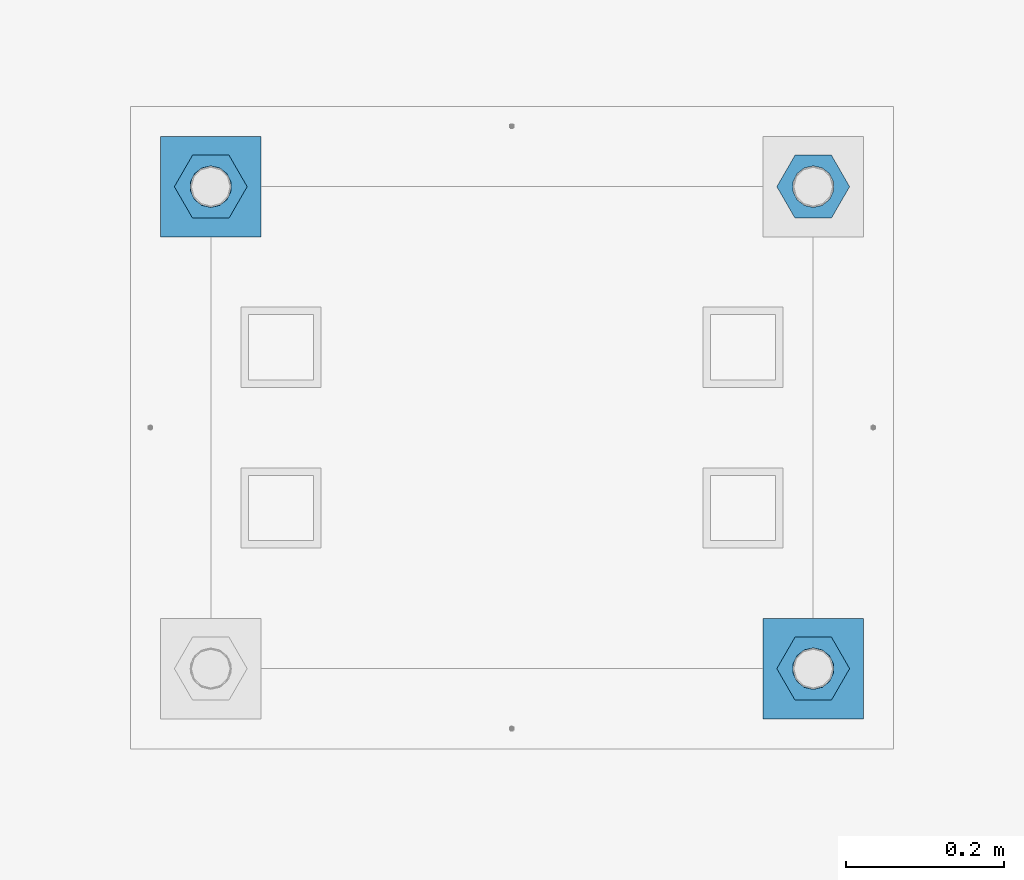
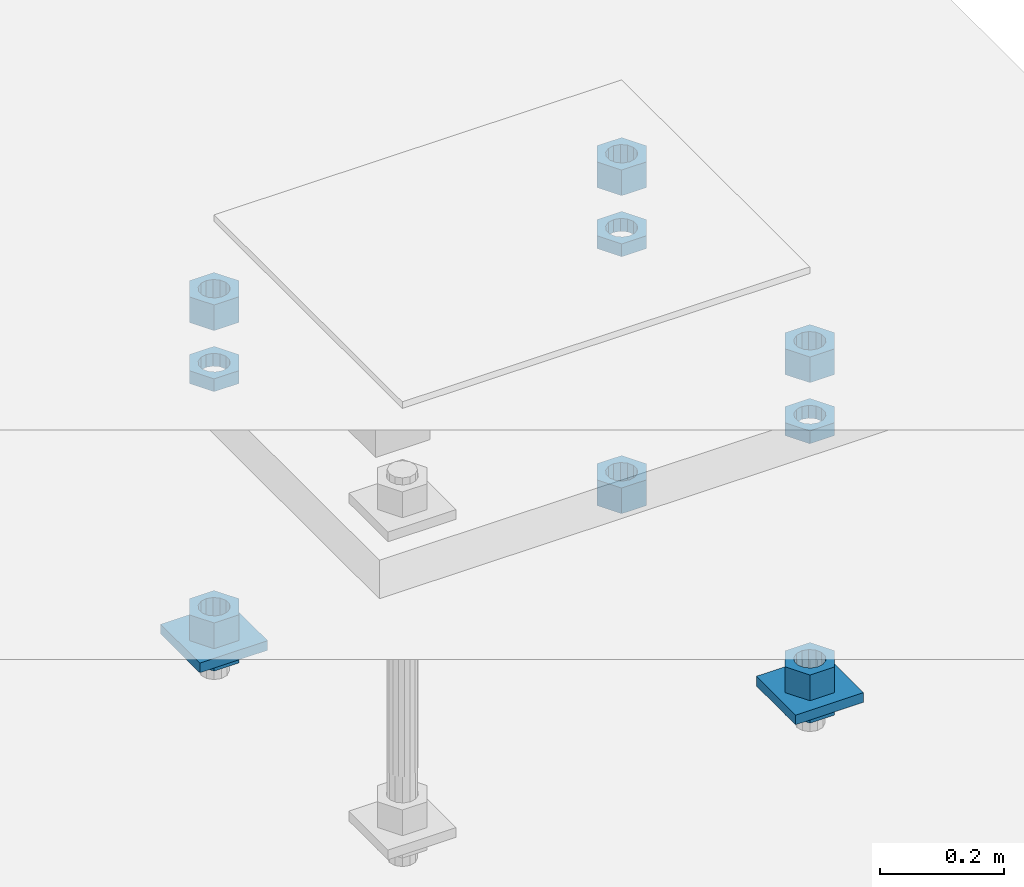
# One storey, part 2635 of 3843: 13 beams, 1 element without a shape of its own.
"""IFC2X3 building model written with IfcOpenShell, lengths in millimetres."""

import ifcopenshell
import ifcopenshell.guid

model = None  # the IFC model being written
_history = None  # IfcOwnerHistory: only IFC2X3 demands one
_inside = {}  # id of a spatial element -> (the spatial element, [elements in it])
_under = {}  # id of a project, library or spatial element -> (it, [spatial elements below it])
_declared = {}  # id of a project -> (the project, [libraries it declares])
_typed = {}  # id of a type object -> (the type object, [elements of that type])
_made_of = {}  # id of a material, layer set ... -> (it, [elements and type objects made of it])


def new_model(schema):
    """Start an empty IFC model of exactly this schema.

    Asked for "IFC4X3", IfcOpenShell would pick the latest addendum, in which some entities
    have other attributes; the version numbers below select the first issue.
    IFC2X3 requires an IfcOwnerHistory on every rooted entity: one is made here for all.
    """
    global model, _history
    if schema == "IFC4X3":
        model = ifcopenshell.file(schema_version=(4, 3, 0, 0))
    else:
        model = ifcopenshell.file(schema=schema)
    _inside.clear()
    _under.clear()
    _declared.clear()
    _typed.clear()
    _made_of.clear()
    _history = None
    if model.schema == "IFC2X3":
        org = make("IfcOrganization", Name="unknown")
        user = make(
            "IfcPersonAndOrganization",
            ThePerson=make("IfcPerson", FamilyName="unknown"),
            TheOrganization=org,
        )
        app = make(
            "IfcApplication",
            ApplicationDeveloper=org,
            Version="unknown",
            ApplicationFullName="unknown",
            ApplicationIdentifier="unknown",
        )
        _history = make(
            "IfcOwnerHistory",
            OwningUser=user,
            OwningApplication=app,
            ChangeAction="ADDED",
            CreationDate=0,
        )
    return model


def make(cls, **values):
    """One entity of the class cls with the attributes given. An attribute that is None is left unset."""
    return model.create_entity(
        cls, **{name: value for name, value in values.items() if value is not None}
    )


def rooted(cls, **values):
    """An entity with a GlobalId (a new one), such as an element, a storey or a relation."""
    return make(cls, GlobalId=ifcopenshell.guid.new(), OwnerHistory=_history, **values)


def si_unit(unit_type, name, prefix=None):
    """IfcSIUnit, for example si_unit("LENGTHUNIT", "METRE", prefix="MILLI")."""
    return make("IfcSIUnit", UnitType=unit_type, Prefix=prefix, Name=name)


def assignment(units):
    """IfcUnitAssignment: the units of a project."""
    return None if units is None else make("IfcUnitAssignment", Units=units)


def point(xyz):
    """IfcCartesianPoint."""
    return None if xyz is None else make("IfcCartesianPoint", Coordinates=xyz)


def direction(xyz):
    """IfcDirection."""
    return None if xyz is None else make("IfcDirection", DirectionRatios=xyz)


def frame(location, z_axis=None, x_axis=None):
    """IfcAxis2Placement3D, a coordinate frame: its origin and axes. An axis left out is left unset."""
    return make(
        "IfcAxis2Placement3D",
        Location=point(location),
        Axis=direction(z_axis),
        RefDirection=direction(x_axis),
    )


def origin_with_axes():
    """The frame at (0, 0, 0) with the z axis (0, 0, 1) and the x axis (1, 0, 0) written out."""
    return frame((0.0, 0.0, 0.0), z_axis=(0.0, 0.0, 1.0), x_axis=(1.0, 0.0, 0.0))


def place(relative_to, where):
    """IfcLocalPlacement: puts the frame where relative to a parent placement (None: the world)."""
    return make(
        "IfcLocalPlacement", PlacementRelTo=relative_to, RelativePlacement=where
    )


def context(
    kind, dimensions, precision=None, world=None, true_north=None, identifier=None
):
    """IfcGeometricRepresentationContext, for example the 3D "Model" context."""
    return make(
        "IfcGeometricRepresentationContext",
        ContextIdentifier=identifier,
        ContextType=kind,
        CoordinateSpaceDimension=dimensions,
        Precision=precision,
        WorldCoordinateSystem=world,
        TrueNorth=true_north,
    )


def subcontext(parent, identifier, kind, view, scale=None):
    """IfcGeometricRepresentationSubContext, for example "Body" below "Model"."""
    return make(
        "IfcGeometricRepresentationSubContext",
        ContextIdentifier=identifier,
        ContextType=kind,
        ParentContext=parent,
        TargetScale=scale,
        TargetView=view,
    )


def project(units=None, contexts=None):
    """IfcProject with its units and contexts."""
    return rooted(
        "IfcProject",
        Name="project",
        RepresentationContexts=contexts,
        UnitsInContext=assignment(units),
    )


def spatial(cls, under=None, at=None, **own):
    """A site, building, storey or space (cls), placed at a placement, below another one or the project."""
    s = rooted(cls, ObjectPlacement=at, **own)
    if under is not None:
        _under.setdefault(under.id(), (under, []))[1].append(s)
    return s


def faces_of(points, faces, orient=None, outer=None):
    """IfcFace entities. A face is a list of loops; a loop is a list of indices into points, from 0.

    orient and outer hold one flag for each loop. By default every Orientation is true, the
    first loop of a face is its IfcFaceOuterBound and the others are IfcFaceBound.
    """
    made = []
    for i, loops in enumerate(faces):
        bounds = []
        for j, loop in enumerate(loops):
            is_outer = j == 0 if outer is None else outer[i][j]
            bounds.append(
                make(
                    "IfcFaceOuterBound" if is_outer else "IfcFaceBound",
                    Bound=make("IfcPolyLoop", Polygon=[points[k] for k in loop]),
                    Orientation=True if orient is None else orient[i][j],
                )
            )
        made.append(make("IfcFace", Bounds=bounds))
    return made


def faceted_brep(points, faces, orient=None, outer=None, voids=None):
    """IfcFacetedBrep: a solid bounded by flat faces; with voids (closed shells), ...WithVoids."""
    shared = [point(p) for p in points]
    hull = make("IfcClosedShell", CfsFaces=faces_of(shared, faces, orient, outer))
    if voids is None:
        return make("IfcFacetedBrep", Outer=hull)
    return make(
        "IfcFacetedBrepWithVoids",
        Outer=hull,
        Voids=[
            make(cls, CfsFaces=faces_of(shared, fs, o, b)) for cls, fs, o, b in voids
        ],
    )


def shape(context_of_items, identifier, shape_type, items):
    """IfcShapeRepresentation: the items that make up one representation, for example the "Body"."""
    return make(
        "IfcShapeRepresentation",
        ContextOfItems=context_of_items,
        RepresentationIdentifier=identifier,
        RepresentationType=shape_type,
        Items=items,
    )


def material(Name=None, Category=None):
    """IfcMaterial."""
    return make("IfcMaterial", Name=Name, Category=Category)


def made_of(thing, what):
    """Note that an element or type object is made of a material, layer set ...; save() writes the relation."""
    if what is not None:
        _made_of.setdefault(what.id(), (what, []))[1].append(thing)
    return thing


def type_object(cls, material=None, **own):
    """A type object (cls), such as IfcWallType, which elements share."""
    return made_of(rooted(cls, **own), material)


def element(
    cls,
    number,
    at=None,
    inside=None,
    cuts=None,
    type_object=None,
    material=None,
    context=None,
    identifier="Body",
    shape_type=None,
    held_by="IfcProductDefinitionShape",
    body=None,
    shapes=None,
    **own,
):
    """One element of the class cls, such as IfcWall. Its Tag is "e" and its number.

    at: its placement. inside: the storey or other place that contains it. cuts: it is an
    opening in that element (IfcRelVoidsElement). A single representation is given by context,
    identifier, shape_type and body (its items); several are given by shapes. held_by: the class
    of the entity that holds the representations. save() writes the other relations.
    """
    e = rooted(cls, Tag="e%d" % number, ObjectPlacement=at, **own)
    if body is not None:
        shapes = [shape(context, identifier, shape_type, body)]
    if shapes is not None:
        e.Representation = make(held_by, Representations=shapes)
    if inside is not None:
        _inside.setdefault(inside.id(), (inside, []))[1].append(e)
    if cuts is not None:
        rooted(
            "IfcRelVoidsElement", RelatingBuildingElement=cuts, RelatedOpeningElement=e
        )
    if type_object is not None:
        _typed.setdefault(type_object.id(), (type_object, []))[1].append(e)
    return made_of(e, material)


def aggregate(whole, parts):
    """IfcRelAggregates: a whole, such as a stair, and the parts it consists of."""
    return rooted("IfcRelAggregates", RelatingObject=whole, RelatedObjects=parts)


def save(model, path):
    """Write the relations noted so far, then the file.

    IfcRelAggregates (storeys below a building ...), IfcRelContainedInSpatialStructure (elements
    in a storey), IfcRelDefinesByType, IfcRelAssociatesMaterial and IfcRelDeclares: one each for
    every whole, place, type object, material and project.
    """
    for whole, parts in _under.values():
        aggregate(whole, parts)
    for where, things in _inside.values():
        rooted(
            "IfcRelContainedInSpatialStructure",
            RelatedElements=things,
            RelatingStructure=where,
        )
    for kind, things in _typed.values():
        rooted("IfcRelDefinesByType", RelatedObjects=things, RelatingType=kind)
    for what, things in _made_of.values():
        rooted("IfcRelAssociatesMaterial", RelatedObjects=things, RelatingMaterial=what)
    for by, libraries in _declared.values():
        rooted("IfcRelDeclares", RelatingContext=by, RelatedDefinitions=libraries)
    model.write(path)


model = new_model("IFC2X3")

# Units and contexts
model_context = context("Model", 3, precision=1e-05, world=origin_with_axes())
body_context = subcontext(model_context, "Body", "Model", "MODEL_VIEW")
ifc_project = project(units=[si_unit("LENGTHUNIT", "METRE", prefix="MILLI"), si_unit("AREAUNIT", "SQUARE_METRE"), si_unit("VOLUMEUNIT", "CUBIC_METRE"), si_unit("MASSUNIT", "GRAM", prefix="KILO"), si_unit("TIMEUNIT", "SECOND"), si_unit("PLANEANGLEUNIT", "RADIAN"), si_unit("SOLIDANGLEUNIT", "STERADIAN"), si_unit("THERMODYNAMICTEMPERATUREUNIT", "DEGREE_CELSIUS"), si_unit("LUMINOUSINTENSITYUNIT", "LUMEN")], contexts=[model_context])

# Site, building, storey
site_placement = place(None, origin_with_axes())
site = spatial("IfcSite", under=ifc_project, at=site_placement, CompositionType="ELEMENT")
building_placement = place(site_placement, origin_with_axes())
building = spatial("IfcBuilding", under=site, at=building_placement, Name="Undefined", CompositionType="ELEMENT")
storey_placement = place(building_placement, origin_with_axes())
storey = spatial("IfcBuildingStorey", under=building, at=storey_placement, Name="Undefined", CompositionType="ELEMENT", Elevation=0.0)

# Assembly, beams
assembly_placement = place(storey_placement, origin_with_axes())
assembly = element("IfcElementAssembly", 1, at=assembly_placement, inside=storey, Name="TEMPLATE", AssemblyPlace="NOTDEFINED", PredefinedType="RIGID_FRAME")
ifc_material_1 = material(Name="STEEL/A572-50")
beam_type_1 = type_object("IfcBeamType", PredefinedType="NOTDEFINED")
beam_1_placement = place(assembly_placement, frame((119227.6, 2819.40000152587, 29244.925), z_axis=(1.0, 0.0, 0.0), x_axis=(0.0, 1.0, 0.0)))
beam_1 = element("IfcBeam", 2, at=beam_1_placement, type_object=beam_type_1, material=ifc_material_1, Name="WASHER_PLATE", context=body_context, shape_type="Brep", body=[
    faceted_brep([(0.0, 9.52500000000146, -63.5), (0.0, 9.52500000000146, 63.5), (127.0, 9.52500000000146, 63.5), (127.0, 9.52500000000146, -63.5), (0.0, -9.52500000000146, 63.5), (127.0, -9.52500000000146, 63.5), (0.0, -9.52500000000146, -63.5), (127.0, -9.52500000000146, -63.5)], [[[0, 1, 2, 3]], [[1, 4, 5, 2]], [[4, 6, 7, 5]], [[6, 0, 3, 7]], [[5, 7, 3, 2]], [[6, 4, 1, 0]]]),
])
beam_2_placement = place(assembly_placement, frame((118465.6, 3429.00000152587, 29244.925), z_axis=(1.0, 0.0, 0.0), x_axis=(0.0, 1.0, 0.0)))
beam_2 = element("IfcBeam", 3, at=beam_2_placement, type_object=beam_type_1, material=ifc_material_1, Name="WASHER_PLATE", context=body_context, shape_type="Brep", body=[
    faceted_brep([(0.0, 9.52500000000146, -63.5), (0.0, 9.52500000000146, 63.5), (127.0, 9.52500000000146, 63.5), (127.0, 9.52500000000146, -63.5), (0.0, -9.52500000000146, 63.5), (127.0, -9.52500000000146, 63.5), (0.0, -9.52500000000146, -63.5), (127.0, -9.52500000000146, -63.5)], [[[0, 1, 2, 3]], [[1, 4, 5, 2]], [[4, 6, 7, 5]], [[6, 0, 3, 7]], [[5, 7, 3, 2]], [[6, 4, 1, 0]]]),
])
ifc_material_2 = material(Name="STEEL/A36")
beam_type_2 = type_object("IfcBeamType", Name="2_HALF_NUT", PredefinedType="NOTDEFINED")
beam_3_placement = place(assembly_placement, frame((119227.6, 2882.90000152587, 29787.85), z_axis=(0.0, 1.0, 0.0), x_axis=(0.0, 0.0, -1.0)))
beam_3 = element("IfcBeam", 4, at=beam_3_placement, type_object=beam_type_2, material=ifc_material_2, Name="NUT", ObjectType="2_HALF_NUT", context=body_context, shape_type="Brep", body=[
    faceted_brep([(0.0, -46.0369987487793, 0.0), (0.0, -23.0184993743896, -39.869213104248), (25.4000000000015, -23.0184993743896, -39.869213104248), (25.4000000000015, -46.0369987487793, 0.0), (0.0, 23.0184993743896, -39.869213104248), (25.4000000000015, 23.0184993743896, -39.869213104248), (0.0, 46.0369987487793, 0.0), (25.4000000000015, 46.0369987487793, 0.0), (0.0, 23.0184993743896, 39.869213104248), (25.4000000000015, 23.0184993743896, 39.869213104248), (0.0, -23.0184993743896, 39.869213104248), (25.4000000000015, -23.0184993743896, 39.869213104248), (0.0, 0.0, 26.1940002441406), (0.0, 11.3650617044477, 23.5999013092805), (25.4000000000015, 11.3650617044477, 23.5999013092805), (25.4000000000015, 0.0, 26.1940002441406), (0.0, 20.4791109456419, 16.3316083006721), (25.4000000000015, 20.4791109456419, 16.3316083006721), (0.0, 25.5370200498292, 5.82867859874386), (25.4000000000015, 25.5370200498292, 5.82867859874386), (0.0, 25.5370200498292, -5.82867859874386), (25.4000000000015, 25.5370200498292, -5.82867859874386), (0.0, 20.4791109456419, -16.3316083006721), (25.4000000000015, 20.4791109456419, -16.3316083006721), (0.0, 11.3650617044477, -23.5999013092805), (25.4000000000015, 11.3650617044477, -23.5999013092805), (0.0, 0.0, -26.1940002441406), (25.4000000000015, 0.0, -26.1940002441406), (0.0, -11.3650617044477, -23.5999013092805), (25.4000000000015, -11.3650617044477, -23.5999013092805), (0.0, -20.4791109456419, -16.3316083006721), (25.4000000000015, -20.4791109456419, -16.3316083006721), (0.0, -25.5370200498292, -5.82867859874386), (25.4000000000015, -25.5370200498292, -5.82867859874386), (0.0, -25.5370200498292, 5.82867859874386), (25.4000000000015, -25.5370200498292, 5.82867859874386), (0.0, -20.4791109456419, 16.3316083006721), (25.4000000000015, -20.4791109456419, 16.3316083006721), (0.0, -11.3650617044477, 23.5999013092805), (25.4000000000015, -11.3650617044477, 23.5999013092805)], [[[0, 1, 2, 3]], [[1, 4, 5, 2]], [[4, 6, 7, 5]], [[6, 8, 9, 7]], [[8, 10, 11, 9]], [[10, 0, 3, 11]], [[12, 13, 14, 15]], [[13, 16, 17, 14]], [[16, 18, 19, 17]], [[18, 20, 21, 19]], [[20, 22, 23, 21]], [[22, 24, 25, 23]], [[24, 26, 27, 25]], [[26, 28, 29, 27]], [[28, 30, 31, 29]], [[30, 32, 33, 31]], [[32, 34, 35, 33]], [[34, 36, 37, 35]], [[36, 38, 39, 37]], [[38, 12, 15, 39]], [[5, 7, 9, 11, 3, 2], [17, 19, 21, 23, 25, 27, 29, 31, 33, 35, 37, 39, 15, 14]], [[10, 8, 6, 4, 1, 0], [38, 36, 34, 32, 30, 28, 26, 24, 22, 20, 18, 16, 13, 12]]]),
])
beam_4_placement = place(assembly_placement, frame((119227.6, 2882.90000152587, 29235.4), z_axis=(0.0, 1.0, 0.0), x_axis=(0.0, 0.0, -1.0)))
beam_4 = element("IfcBeam", 5, at=beam_4_placement, type_object=beam_type_2, material=ifc_material_2, Name="NUT", ObjectType="2_HALF_NUT", context=body_context, shape_type="Brep", body=[
    faceted_brep([(0.0, -46.0369987487793, 0.0), (0.0, -23.0184993743896, -39.869213104248), (25.4000000000015, -23.0184993743896, -39.869213104248), (25.4000000000015, -46.0369987487793, 0.0), (0.0, 23.0184993743896, -39.869213104248), (25.4000000000015, 23.0184993743896, -39.869213104248), (0.0, 46.0369987487793, 0.0), (25.4000000000015, 46.0369987487793, 0.0), (0.0, 23.0184993743896, 39.869213104248), (25.4000000000015, 23.0184993743896, 39.869213104248), (0.0, -23.0184993743896, 39.869213104248), (25.4000000000015, -23.0184993743896, 39.869213104248), (0.0, 0.0, 26.1940002441406), (0.0, 11.3650617044477, 23.5999013092805), (25.4000000000015, 11.3650617044477, 23.5999013092805), (25.4000000000015, 0.0, 26.1940002441406), (0.0, 20.4791109456419, 16.3316083006721), (25.4000000000015, 20.4791109456419, 16.3316083006721), (0.0, 25.5370200498292, 5.82867859874386), (25.4000000000015, 25.5370200498292, 5.82867859874386), (0.0, 25.5370200498292, -5.82867859874386), (25.4000000000015, 25.5370200498292, -5.82867859874386), (0.0, 20.4791109456419, -16.3316083006721), (25.4000000000015, 20.4791109456419, -16.3316083006721), (0.0, 11.3650617044477, -23.5999013092805), (25.4000000000015, 11.3650617044477, -23.5999013092805), (0.0, 0.0, -26.1940002441406), (25.4000000000015, 0.0, -26.1940002441406), (0.0, -11.3650617044477, -23.5999013092805), (25.4000000000015, -11.3650617044477, -23.5999013092805), (0.0, -20.4791109456419, -16.3316083006721), (25.4000000000015, -20.4791109456419, -16.3316083006721), (0.0, -25.5370200498292, -5.82867859874386), (25.4000000000015, -25.5370200498292, -5.82867859874386), (0.0, -25.5370200498292, 5.82867859874386), (25.4000000000015, -25.5370200498292, 5.82867859874386), (0.0, -20.4791109456419, 16.3316083006721), (25.4000000000015, -20.4791109456419, 16.3316083006721), (0.0, -11.3650617044477, 23.5999013092805), (25.4000000000015, -11.3650617044477, 23.5999013092805)], [[[0, 1, 2, 3]], [[1, 4, 5, 2]], [[4, 6, 7, 5]], [[6, 8, 9, 7]], [[8, 10, 11, 9]], [[10, 0, 3, 11]], [[12, 13, 14, 15]], [[13, 16, 17, 14]], [[16, 18, 19, 17]], [[18, 20, 21, 19]], [[20, 22, 23, 21]], [[22, 24, 25, 23]], [[24, 26, 27, 25]], [[26, 28, 29, 27]], [[28, 30, 31, 29]], [[30, 32, 33, 31]], [[32, 34, 35, 33]], [[34, 36, 37, 35]], [[36, 38, 39, 37]], [[38, 12, 15, 39]], [[5, 7, 9, 11, 3, 2], [17, 19, 21, 23, 25, 27, 29, 31, 33, 35, 37, 39, 15, 14]], [[10, 8, 6, 4, 1, 0], [38, 36, 34, 32, 30, 28, 26, 24, 22, 20, 18, 16, 13, 12]]]),
])
beam_5_placement = place(assembly_placement, frame((118465.6, 3492.50000152587, 29787.85), z_axis=(0.0, 1.0, 0.0), x_axis=(0.0, 0.0, -1.0)))
beam_5 = element("IfcBeam", 6, at=beam_5_placement, type_object=beam_type_2, material=ifc_material_2, Name="NUT", ObjectType="2_HALF_NUT", context=body_context, shape_type="Brep", body=[
    faceted_brep([(0.0, -46.0369987487793, 0.0), (0.0, -23.0184993743896, -39.869213104248), (25.4000000000015, -23.0184993743896, -39.869213104248), (25.4000000000015, -46.0369987487793, 0.0), (0.0, 23.0184993743896, -39.869213104248), (25.4000000000015, 23.0184993743896, -39.869213104248), (0.0, 46.0369987487793, 0.0), (25.4000000000015, 46.0369987487793, 0.0), (0.0, 23.0184993743896, 39.869213104248), (25.4000000000015, 23.0184993743896, 39.869213104248), (0.0, -23.0184993743896, 39.869213104248), (25.4000000000015, -23.0184993743896, 39.869213104248), (0.0, 0.0, 26.1940002441406), (0.0, 11.3650617044477, 23.5999013092805), (25.4000000000015, 11.3650617044477, 23.5999013092805), (25.4000000000015, 0.0, 26.1940002441406), (0.0, 20.4791109456419, 16.3316083006721), (25.4000000000015, 20.4791109456419, 16.3316083006721), (0.0, 25.5370200498292, 5.82867859874386), (25.4000000000015, 25.5370200498292, 5.82867859874386), (0.0, 25.5370200498292, -5.82867859874386), (25.4000000000015, 25.5370200498292, -5.82867859874386), (0.0, 20.4791109456419, -16.3316083006721), (25.4000000000015, 20.4791109456419, -16.3316083006721), (0.0, 11.3650617044477, -23.5999013092805), (25.4000000000015, 11.3650617044477, -23.5999013092805), (0.0, 0.0, -26.1940002441406), (25.4000000000015, 0.0, -26.1940002441406), (0.0, -11.3650617044477, -23.5999013092805), (25.4000000000015, -11.3650617044477, -23.5999013092805), (0.0, -20.4791109456419, -16.3316083006721), (25.4000000000015, -20.4791109456419, -16.3316083006721), (0.0, -25.5370200498292, -5.82867859874386), (25.4000000000015, -25.5370200498292, -5.82867859874386), (0.0, -25.5370200498292, 5.82867859874386), (25.4000000000015, -25.5370200498292, 5.82867859874386), (0.0, -20.4791109456419, 16.3316083006721), (25.4000000000015, -20.4791109456419, 16.3316083006721), (0.0, -11.3650617044477, 23.5999013092805), (25.4000000000015, -11.3650617044477, 23.5999013092805)], [[[0, 1, 2, 3]], [[1, 4, 5, 2]], [[4, 6, 7, 5]], [[6, 8, 9, 7]], [[8, 10, 11, 9]], [[10, 0, 3, 11]], [[12, 13, 14, 15]], [[13, 16, 17, 14]], [[16, 18, 19, 17]], [[18, 20, 21, 19]], [[20, 22, 23, 21]], [[22, 24, 25, 23]], [[24, 26, 27, 25]], [[26, 28, 29, 27]], [[28, 30, 31, 29]], [[30, 32, 33, 31]], [[32, 34, 35, 33]], [[34, 36, 37, 35]], [[36, 38, 39, 37]], [[38, 12, 15, 39]], [[5, 7, 9, 11, 3, 2], [17, 19, 21, 23, 25, 27, 29, 31, 33, 35, 37, 39, 15, 14]], [[10, 8, 6, 4, 1, 0], [38, 36, 34, 32, 30, 28, 26, 24, 22, 20, 18, 16, 13, 12]]]),
])
beam_6_placement = place(assembly_placement, frame((118465.6, 3492.50000152587, 29235.4), z_axis=(0.0, 1.0, 0.0), x_axis=(0.0, 0.0, -1.0)))
beam_6 = element("IfcBeam", 7, at=beam_6_placement, type_object=beam_type_2, material=ifc_material_2, Name="NUT", ObjectType="2_HALF_NUT", context=body_context, shape_type="Brep", body=[
    faceted_brep([(0.0, -46.0369987487793, 0.0), (0.0, -23.0184993743896, -39.869213104248), (25.4000000000015, -23.0184993743896, -39.869213104248), (25.4000000000015, -46.0369987487793, 0.0), (0.0, 23.0184993743896, -39.869213104248), (25.4000000000015, 23.0184993743896, -39.869213104248), (0.0, 46.0369987487793, 0.0), (25.4000000000015, 46.0369987487793, 0.0), (0.0, 23.0184993743896, 39.869213104248), (25.4000000000015, 23.0184993743896, 39.869213104248), (0.0, -23.0184993743896, 39.869213104248), (25.4000000000015, -23.0184993743896, 39.869213104248), (0.0, 0.0, 26.1940002441406), (0.0, 11.3650617044477, 23.5999013092805), (25.4000000000015, 11.3650617044477, 23.5999013092805), (25.4000000000015, 0.0, 26.1940002441406), (0.0, 20.4791109456419, 16.3316083006721), (25.4000000000015, 20.4791109456419, 16.3316083006721), (0.0, 25.5370200498292, 5.82867859874386), (25.4000000000015, 25.5370200498292, 5.82867859874386), (0.0, 25.5370200498292, -5.82867859874386), (25.4000000000015, 25.5370200498292, -5.82867859874386), (0.0, 20.4791109456419, -16.3316083006721), (25.4000000000015, 20.4791109456419, -16.3316083006721), (0.0, 11.3650617044477, -23.5999013092805), (25.4000000000015, 11.3650617044477, -23.5999013092805), (0.0, 0.0, -26.1940002441406), (25.4000000000015, 0.0, -26.1940002441406), (0.0, -11.3650617044477, -23.5999013092805), (25.4000000000015, -11.3650617044477, -23.5999013092805), (0.0, -20.4791109456419, -16.3316083006721), (25.4000000000015, -20.4791109456419, -16.3316083006721), (0.0, -25.5370200498292, -5.82867859874386), (25.4000000000015, -25.5370200498292, -5.82867859874386), (0.0, -25.5370200498292, 5.82867859874386), (25.4000000000015, -25.5370200498292, 5.82867859874386), (0.0, -20.4791109456419, 16.3316083006721), (25.4000000000015, -20.4791109456419, 16.3316083006721), (0.0, -11.3650617044477, 23.5999013092805), (25.4000000000015, -11.3650617044477, 23.5999013092805)], [[[0, 1, 2, 3]], [[1, 4, 5, 2]], [[4, 6, 7, 5]], [[6, 8, 9, 7]], [[8, 10, 11, 9]], [[10, 0, 3, 11]], [[12, 13, 14, 15]], [[13, 16, 17, 14]], [[16, 18, 19, 17]], [[18, 20, 21, 19]], [[20, 22, 23, 21]], [[22, 24, 25, 23]], [[24, 26, 27, 25]], [[26, 28, 29, 27]], [[28, 30, 31, 29]], [[30, 32, 33, 31]], [[32, 34, 35, 33]], [[34, 36, 37, 35]], [[36, 38, 39, 37]], [[38, 12, 15, 39]], [[5, 7, 9, 11, 3, 2], [17, 19, 21, 23, 25, 27, 29, 31, 33, 35, 37, 39, 15, 14]], [[10, 8, 6, 4, 1, 0], [38, 36, 34, 32, 30, 28, 26, 24, 22, 20, 18, 16, 13, 12]]]),
])
beam_7_placement = place(assembly_placement, frame((119227.6, 3492.50000152587, 29787.85), z_axis=(0.0, 1.0, 0.0), x_axis=(0.0, 0.0, -1.0)))
beam_7 = element("IfcBeam", 8, at=beam_7_placement, type_object=beam_type_2, material=ifc_material_2, Name="NUT", ObjectType="2_HALF_NUT", context=body_context, shape_type="Brep", body=[
    faceted_brep([(0.0, -46.0369987487793, 0.0), (0.0, -23.0184993743896, -39.869213104248), (25.4000000000015, -23.0184993743896, -39.869213104248), (25.4000000000015, -46.0369987487793, 0.0), (0.0, 23.0184993743896, -39.869213104248), (25.4000000000015, 23.0184993743896, -39.869213104248), (0.0, 46.0369987487793, 0.0), (25.4000000000015, 46.0369987487793, 0.0), (0.0, 23.0184993743896, 39.869213104248), (25.4000000000015, 23.0184993743896, 39.869213104248), (0.0, -23.0184993743896, 39.869213104248), (25.4000000000015, -23.0184993743896, 39.869213104248), (0.0, 0.0, 26.1940002441406), (0.0, 11.3650617044477, 23.5999013092805), (25.4000000000015, 11.3650617044477, 23.5999013092805), (25.4000000000015, 0.0, 26.1940002441406), (0.0, 20.4791109456419, 16.3316083006721), (25.4000000000015, 20.4791109456419, 16.3316083006721), (0.0, 25.5370200498292, 5.82867859874386), (25.4000000000015, 25.5370200498292, 5.82867859874386), (0.0, 25.5370200498292, -5.82867859874386), (25.4000000000015, 25.5370200498292, -5.82867859874386), (0.0, 20.4791109456419, -16.3316083006721), (25.4000000000015, 20.4791109456419, -16.3316083006721), (0.0, 11.3650617044477, -23.5999013092805), (25.4000000000015, 11.3650617044477, -23.5999013092805), (0.0, 0.0, -26.1940002441406), (25.4000000000015, 0.0, -26.1940002441406), (0.0, -11.3650617044477, -23.5999013092805), (25.4000000000015, -11.3650617044477, -23.5999013092805), (0.0, -20.4791109456419, -16.3316083006721), (25.4000000000015, -20.4791109456419, -16.3316083006721), (0.0, -25.5370200498292, -5.82867859874386), (25.4000000000015, -25.5370200498292, -5.82867859874386), (0.0, -25.5370200498292, 5.82867859874386), (25.4000000000015, -25.5370200498292, 5.82867859874386), (0.0, -20.4791109456419, 16.3316083006721), (25.4000000000015, -20.4791109456419, 16.3316083006721), (0.0, -11.3650617044477, 23.5999013092805), (25.4000000000015, -11.3650617044477, 23.5999013092805)], [[[0, 1, 2, 3]], [[1, 4, 5, 2]], [[4, 6, 7, 5]], [[6, 8, 9, 7]], [[8, 10, 11, 9]], [[10, 0, 3, 11]], [[12, 13, 14, 15]], [[13, 16, 17, 14]], [[16, 18, 19, 17]], [[18, 20, 21, 19]], [[20, 22, 23, 21]], [[22, 24, 25, 23]], [[24, 26, 27, 25]], [[26, 28, 29, 27]], [[28, 30, 31, 29]], [[30, 32, 33, 31]], [[32, 34, 35, 33]], [[34, 36, 37, 35]], [[36, 38, 39, 37]], [[38, 12, 15, 39]], [[5, 7, 9, 11, 3, 2], [17, 19, 21, 23, 25, 27, 29, 31, 33, 35, 37, 39, 15, 14]], [[10, 8, 6, 4, 1, 0], [38, 36, 34, 32, 30, 28, 26, 24, 22, 20, 18, 16, 13, 12]]]),
])
beam_type_3 = type_object("IfcBeamType", Name="2_HEAVY_HEX_NUT", PredefinedType="NOTDEFINED")
beam_8_placement = place(assembly_placement, frame((119227.6, 2882.90000152587, 29933.9), z_axis=(0.0, 1.0, 0.0), x_axis=(0.0, 0.0, -1.0)))
beam_8 = element("IfcBeam", 9, at=beam_8_placement, type_object=beam_type_3, material=ifc_material_2, Name="NUT", ObjectType="2_HEAVY_HEX_NUT", context=body_context, shape_type="Brep", body=[
    faceted_brep([(0.0, -46.0369987487793, 0.0), (0.0, -23.0184993743896, -39.869213104248), (50.7999999999993, -23.0184993743896, -39.869213104248), (50.7999999999993, -46.0369987487793, 0.0), (0.0, 23.0184993743896, -39.869213104248), (50.7999999999993, 23.0184993743896, -39.869213104248), (0.0, 46.0369987487793, 0.0), (50.7999999999993, 46.0369987487793, 0.0), (0.0, 23.0184993743896, 39.869213104248), (50.7999999999993, 23.0184993743896, 39.869213104248), (0.0, -23.0184993743896, 39.869213104248), (50.7999999999993, -23.0184993743896, 39.869213104248), (0.0, 0.0, 26.1940002441406), (0.0, 11.3650617044477, 23.5999013092805), (50.7999999999993, 11.3650617044477, 23.5999013092805), (50.7999999999993, 0.0, 26.1940002441406), (0.0, 20.4791109456419, 16.3316083006721), (50.7999999999993, 20.4791109456419, 16.3316083006721), (0.0, 25.5370200498292, 5.82867859874386), (50.7999999999993, 25.5370200498292, 5.82867859874386), (0.0, 25.5370200498292, -5.82867859874386), (50.7999999999993, 25.5370200498292, -5.82867859874386), (0.0, 20.4791109456419, -16.3316083006721), (50.7999999999993, 20.4791109456419, -16.3316083006721), (0.0, 11.3650617044477, -23.5999013092805), (50.7999999999993, 11.3650617044477, -23.5999013092805), (0.0, 0.0, -26.1940002441406), (50.7999999999993, 0.0, -26.1940002441406), (0.0, -11.3650617044477, -23.5999013092805), (50.7999999999993, -11.3650617044477, -23.5999013092805), (0.0, -20.4791109456419, -16.3316083006721), (50.7999999999993, -20.4791109456419, -16.3316083006721), (0.0, -25.5370200498292, -5.82867859874386), (50.7999999999993, -25.5370200498292, -5.82867859874386), (0.0, -25.5370200498292, 5.82867859874386), (50.7999999999993, -25.5370200498292, 5.82867859874386), (0.0, -20.4791109456419, 16.3316083006721), (50.7999999999993, -20.4791109456419, 16.3316083006721), (0.0, -11.3650617044477, 23.5999013092805), (50.7999999999993, -11.3650617044477, 23.5999013092805)], [[[0, 1, 2, 3]], [[1, 4, 5, 2]], [[4, 6, 7, 5]], [[6, 8, 9, 7]], [[8, 10, 11, 9]], [[10, 0, 3, 11]], [[12, 13, 14, 15]], [[13, 16, 17, 14]], [[16, 18, 19, 17]], [[18, 20, 21, 19]], [[20, 22, 23, 21]], [[22, 24, 25, 23]], [[24, 26, 27, 25]], [[26, 28, 29, 27]], [[28, 30, 31, 29]], [[30, 32, 33, 31]], [[32, 34, 35, 33]], [[34, 36, 37, 35]], [[36, 38, 39, 37]], [[38, 12, 15, 39]], [[5, 7, 9, 11, 3, 2], [17, 19, 21, 23, 25, 27, 29, 31, 33, 35, 37, 39, 15, 14]], [[10, 8, 6, 4, 1, 0], [38, 36, 34, 32, 30, 28, 26, 24, 22, 20, 18, 16, 13, 12]]]),
])
beam_9_placement = place(assembly_placement, frame((119227.6, 2882.90000152587, 29305.25), z_axis=(0.0, 1.0, 0.0), x_axis=(0.0, 0.0, -1.0)))
beam_9 = element("IfcBeam", 10, at=beam_9_placement, type_object=beam_type_3, material=ifc_material_2, Name="NUT", ObjectType="2_HEAVY_HEX_NUT", context=body_context, shape_type="Brep", body=[
    faceted_brep([(0.0, -46.0369987487793, 0.0), (0.0, -23.0184993743896, -39.869213104248), (50.7999999999993, -23.0184993743896, -39.869213104248), (50.7999999999993, -46.0369987487793, 0.0), (0.0, 23.0184993743896, -39.869213104248), (50.7999999999993, 23.0184993743896, -39.869213104248), (0.0, 46.0369987487793, 0.0), (50.7999999999993, 46.0369987487793, 0.0), (0.0, 23.0184993743896, 39.869213104248), (50.7999999999993, 23.0184993743896, 39.869213104248), (0.0, -23.0184993743896, 39.869213104248), (50.7999999999993, -23.0184993743896, 39.869213104248), (0.0, 0.0, 26.1940002441406), (0.0, 11.3650617044477, 23.5999013092805), (50.7999999999993, 11.3650617044477, 23.5999013092805), (50.7999999999993, 0.0, 26.1940002441406), (0.0, 20.4791109456419, 16.3316083006721), (50.7999999999993, 20.4791109456419, 16.3316083006721), (0.0, 25.5370200498292, 5.82867859874386), (50.7999999999993, 25.5370200498292, 5.82867859874386), (0.0, 25.5370200498292, -5.82867859874386), (50.7999999999993, 25.5370200498292, -5.82867859874386), (0.0, 20.4791109456419, -16.3316083006721), (50.7999999999993, 20.4791109456419, -16.3316083006721), (0.0, 11.3650617044477, -23.5999013092805), (50.7999999999993, 11.3650617044477, -23.5999013092805), (0.0, 0.0, -26.1940002441406), (50.7999999999993, 0.0, -26.1940002441406), (0.0, -11.3650617044477, -23.5999013092805), (50.7999999999993, -11.3650617044477, -23.5999013092805), (0.0, -20.4791109456419, -16.3316083006721), (50.7999999999993, -20.4791109456419, -16.3316083006721), (0.0, -25.5370200498292, -5.82867859874386), (50.7999999999993, -25.5370200498292, -5.82867859874386), (0.0, -25.5370200498292, 5.82867859874386), (50.7999999999993, -25.5370200498292, 5.82867859874386), (0.0, -20.4791109456419, 16.3316083006721), (50.7999999999993, -20.4791109456419, 16.3316083006721), (0.0, -11.3650617044477, 23.5999013092805), (50.7999999999993, -11.3650617044477, 23.5999013092805)], [[[0, 1, 2, 3]], [[1, 4, 5, 2]], [[4, 6, 7, 5]], [[6, 8, 9, 7]], [[8, 10, 11, 9]], [[10, 0, 3, 11]], [[12, 13, 14, 15]], [[13, 16, 17, 14]], [[16, 18, 19, 17]], [[18, 20, 21, 19]], [[20, 22, 23, 21]], [[22, 24, 25, 23]], [[24, 26, 27, 25]], [[26, 28, 29, 27]], [[28, 30, 31, 29]], [[30, 32, 33, 31]], [[32, 34, 35, 33]], [[34, 36, 37, 35]], [[36, 38, 39, 37]], [[38, 12, 15, 39]], [[5, 7, 9, 11, 3, 2], [17, 19, 21, 23, 25, 27, 29, 31, 33, 35, 37, 39, 15, 14]], [[10, 8, 6, 4, 1, 0], [38, 36, 34, 32, 30, 28, 26, 24, 22, 20, 18, 16, 13, 12]]]),
])
beam_10_placement = place(assembly_placement, frame((118465.6, 3492.50000152587, 29933.9), z_axis=(0.0, 1.0, 0.0), x_axis=(0.0, 0.0, -1.0)))
beam_10 = element("IfcBeam", 11, at=beam_10_placement, type_object=beam_type_3, material=ifc_material_2, Name="NUT", ObjectType="2_HEAVY_HEX_NUT", context=body_context, shape_type="Brep", body=[
    faceted_brep([(0.0, -46.0369987487793, 0.0), (0.0, -23.0184993743896, -39.869213104248), (50.7999999999993, -23.0184993743896, -39.869213104248), (50.7999999999993, -46.0369987487793, 0.0), (0.0, 23.0184993743896, -39.869213104248), (50.7999999999993, 23.0184993743896, -39.869213104248), (0.0, 46.0369987487793, 0.0), (50.7999999999993, 46.0369987487793, 0.0), (0.0, 23.0184993743896, 39.869213104248), (50.7999999999993, 23.0184993743896, 39.869213104248), (0.0, -23.0184993743896, 39.869213104248), (50.7999999999993, -23.0184993743896, 39.869213104248), (0.0, 0.0, 26.1940002441406), (0.0, 11.3650617044477, 23.5999013092805), (50.7999999999993, 11.3650617044477, 23.5999013092805), (50.7999999999993, 0.0, 26.1940002441406), (0.0, 20.4791109456419, 16.3316083006721), (50.7999999999993, 20.4791109456419, 16.3316083006721), (0.0, 25.5370200498292, 5.82867859874386), (50.7999999999993, 25.5370200498292, 5.82867859874386), (0.0, 25.5370200498292, -5.82867859874386), (50.7999999999993, 25.5370200498292, -5.82867859874386), (0.0, 20.4791109456419, -16.3316083006721), (50.7999999999993, 20.4791109456419, -16.3316083006721), (0.0, 11.3650617044477, -23.5999013092805), (50.7999999999993, 11.3650617044477, -23.5999013092805), (0.0, 0.0, -26.1940002441406), (50.7999999999993, 0.0, -26.1940002441406), (0.0, -11.3650617044477, -23.5999013092805), (50.7999999999993, -11.3650617044477, -23.5999013092805), (0.0, -20.4791109456419, -16.3316083006721), (50.7999999999993, -20.4791109456419, -16.3316083006721), (0.0, -25.5370200498292, -5.82867859874386), (50.7999999999993, -25.5370200498292, -5.82867859874386), (0.0, -25.5370200498292, 5.82867859874386), (50.7999999999993, -25.5370200498292, 5.82867859874386), (0.0, -20.4791109456419, 16.3316083006721), (50.7999999999993, -20.4791109456419, 16.3316083006721), (0.0, -11.3650617044477, 23.5999013092805), (50.7999999999993, -11.3650617044477, 23.5999013092805)], [[[0, 1, 2, 3]], [[1, 4, 5, 2]], [[4, 6, 7, 5]], [[6, 8, 9, 7]], [[8, 10, 11, 9]], [[10, 0, 3, 11]], [[12, 13, 14, 15]], [[13, 16, 17, 14]], [[16, 18, 19, 17]], [[18, 20, 21, 19]], [[20, 22, 23, 21]], [[22, 24, 25, 23]], [[24, 26, 27, 25]], [[26, 28, 29, 27]], [[28, 30, 31, 29]], [[30, 32, 33, 31]], [[32, 34, 35, 33]], [[34, 36, 37, 35]], [[36, 38, 39, 37]], [[38, 12, 15, 39]], [[5, 7, 9, 11, 3, 2], [17, 19, 21, 23, 25, 27, 29, 31, 33, 35, 37, 39, 15, 14]], [[10, 8, 6, 4, 1, 0], [38, 36, 34, 32, 30, 28, 26, 24, 22, 20, 18, 16, 13, 12]]]),
])
beam_11_placement = place(assembly_placement, frame((118465.6, 3492.50000152587, 29305.25), z_axis=(0.0, 1.0, 0.0), x_axis=(0.0, 0.0, -1.0)))
beam_11 = element("IfcBeam", 12, at=beam_11_placement, type_object=beam_type_3, material=ifc_material_2, Name="NUT", ObjectType="2_HEAVY_HEX_NUT", context=body_context, shape_type="Brep", body=[
    faceted_brep([(0.0, -46.0369987487793, 0.0), (0.0, -23.0184993743896, -39.869213104248), (50.7999999999993, -23.0184993743896, -39.869213104248), (50.7999999999993, -46.0369987487793, 0.0), (0.0, 23.0184993743896, -39.869213104248), (50.7999999999993, 23.0184993743896, -39.869213104248), (0.0, 46.0369987487793, 0.0), (50.7999999999993, 46.0369987487793, 0.0), (0.0, 23.0184993743896, 39.869213104248), (50.7999999999993, 23.0184993743896, 39.869213104248), (0.0, -23.0184993743896, 39.869213104248), (50.7999999999993, -23.0184993743896, 39.869213104248), (0.0, 0.0, 26.1940002441406), (0.0, 11.3650617044477, 23.5999013092805), (50.7999999999993, 11.3650617044477, 23.5999013092805), (50.7999999999993, 0.0, 26.1940002441406), (0.0, 20.4791109456419, 16.3316083006721), (50.7999999999993, 20.4791109456419, 16.3316083006721), (0.0, 25.5370200498292, 5.82867859874386), (50.7999999999993, 25.5370200498292, 5.82867859874386), (0.0, 25.5370200498292, -5.82867859874386), (50.7999999999993, 25.5370200498292, -5.82867859874386), (0.0, 20.4791109456419, -16.3316083006721), (50.7999999999993, 20.4791109456419, -16.3316083006721), (0.0, 11.3650617044477, -23.5999013092805), (50.7999999999993, 11.3650617044477, -23.5999013092805), (0.0, 0.0, -26.1940002441406), (50.7999999999993, 0.0, -26.1940002441406), (0.0, -11.3650617044477, -23.5999013092805), (50.7999999999993, -11.3650617044477, -23.5999013092805), (0.0, -20.4791109456419, -16.3316083006721), (50.7999999999993, -20.4791109456419, -16.3316083006721), (0.0, -25.5370200498292, -5.82867859874386), (50.7999999999993, -25.5370200498292, -5.82867859874386), (0.0, -25.5370200498292, 5.82867859874386), (50.7999999999993, -25.5370200498292, 5.82867859874386), (0.0, -20.4791109456419, 16.3316083006721), (50.7999999999993, -20.4791109456419, 16.3316083006721), (0.0, -11.3650617044477, 23.5999013092805), (50.7999999999993, -11.3650617044477, 23.5999013092805)], [[[0, 1, 2, 3]], [[1, 4, 5, 2]], [[4, 6, 7, 5]], [[6, 8, 9, 7]], [[8, 10, 11, 9]], [[10, 0, 3, 11]], [[12, 13, 14, 15]], [[13, 16, 17, 14]], [[16, 18, 19, 17]], [[18, 20, 21, 19]], [[20, 22, 23, 21]], [[22, 24, 25, 23]], [[24, 26, 27, 25]], [[26, 28, 29, 27]], [[28, 30, 31, 29]], [[30, 32, 33, 31]], [[32, 34, 35, 33]], [[34, 36, 37, 35]], [[36, 38, 39, 37]], [[38, 12, 15, 39]], [[5, 7, 9, 11, 3, 2], [17, 19, 21, 23, 25, 27, 29, 31, 33, 35, 37, 39, 15, 14]], [[10, 8, 6, 4, 1, 0], [38, 36, 34, 32, 30, 28, 26, 24, 22, 20, 18, 16, 13, 12]]]),
])
beam_12_placement = place(assembly_placement, frame((119227.6, 3492.50000152587, 29933.9), z_axis=(0.0, 1.0, 0.0), x_axis=(0.0, 0.0, -1.0)))
beam_12 = element("IfcBeam", 13, at=beam_12_placement, type_object=beam_type_3, material=ifc_material_2, Name="NUT", ObjectType="2_HEAVY_HEX_NUT", context=body_context, shape_type="Brep", body=[
    faceted_brep([(0.0, -46.0369987487793, 0.0), (0.0, -23.0184993743896, -39.869213104248), (50.7999999999993, -23.0184993743896, -39.869213104248), (50.7999999999993, -46.0369987487793, 0.0), (0.0, 23.0184993743896, -39.869213104248), (50.7999999999993, 23.0184993743896, -39.869213104248), (0.0, 46.0369987487793, 0.0), (50.7999999999993, 46.0369987487793, 0.0), (0.0, 23.0184993743896, 39.869213104248), (50.7999999999993, 23.0184993743896, 39.869213104248), (0.0, -23.0184993743896, 39.869213104248), (50.7999999999993, -23.0184993743896, 39.869213104248), (0.0, 0.0, 26.1940002441406), (0.0, 11.3650617044477, 23.5999013092805), (50.7999999999993, 11.3650617044477, 23.5999013092805), (50.7999999999993, 0.0, 26.1940002441406), (0.0, 20.4791109456419, 16.3316083006721), (50.7999999999993, 20.4791109456419, 16.3316083006721), (0.0, 25.5370200498292, 5.82867859874386), (50.7999999999993, 25.5370200498292, 5.82867859874386), (0.0, 25.5370200498292, -5.82867859874386), (50.7999999999993, 25.5370200498292, -5.82867859874386), (0.0, 20.4791109456419, -16.3316083006721), (50.7999999999993, 20.4791109456419, -16.3316083006721), (0.0, 11.3650617044477, -23.5999013092805), (50.7999999999993, 11.3650617044477, -23.5999013092805), (0.0, 0.0, -26.1940002441406), (50.7999999999993, 0.0, -26.1940002441406), (0.0, -11.3650617044477, -23.5999013092805), (50.7999999999993, -11.3650617044477, -23.5999013092805), (0.0, -20.4791109456419, -16.3316083006721), (50.7999999999993, -20.4791109456419, -16.3316083006721), (0.0, -25.5370200498292, -5.82867859874386), (50.7999999999993, -25.5370200498292, -5.82867859874386), (0.0, -25.5370200498292, 5.82867859874386), (50.7999999999993, -25.5370200498292, 5.82867859874386), (0.0, -20.4791109456419, 16.3316083006721), (50.7999999999993, -20.4791109456419, 16.3316083006721), (0.0, -11.3650617044477, 23.5999013092805), (50.7999999999993, -11.3650617044477, 23.5999013092805)], [[[0, 1, 2, 3]], [[1, 4, 5, 2]], [[4, 6, 7, 5]], [[6, 8, 9, 7]], [[8, 10, 11, 9]], [[10, 0, 3, 11]], [[12, 13, 14, 15]], [[13, 16, 17, 14]], [[16, 18, 19, 17]], [[18, 20, 21, 19]], [[20, 22, 23, 21]], [[22, 24, 25, 23]], [[24, 26, 27, 25]], [[26, 28, 29, 27]], [[28, 30, 31, 29]], [[30, 32, 33, 31]], [[32, 34, 35, 33]], [[34, 36, 37, 35]], [[36, 38, 39, 37]], [[38, 12, 15, 39]], [[5, 7, 9, 11, 3, 2], [17, 19, 21, 23, 25, 27, 29, 31, 33, 35, 37, 39, 15, 14]], [[10, 8, 6, 4, 1, 0], [38, 36, 34, 32, 30, 28, 26, 24, 22, 20, 18, 16, 13, 12]]]),
])
beam_13_placement = place(assembly_placement, frame((119227.6, 3492.50000152587, 29305.25), z_axis=(0.0, 1.0, 0.0), x_axis=(0.0, 0.0, -1.0)))
beam_13 = element("IfcBeam", 14, at=beam_13_placement, type_object=beam_type_3, material=ifc_material_2, Name="NUT", ObjectType="2_HEAVY_HEX_NUT", context=body_context, shape_type="Brep", body=[
    faceted_brep([(0.0, -46.0369987487793, 0.0), (0.0, -23.0184993743896, -39.869213104248), (50.7999999999993, -23.0184993743896, -39.869213104248), (50.7999999999993, -46.0369987487793, 0.0), (0.0, 23.0184993743896, -39.869213104248), (50.7999999999993, 23.0184993743896, -39.869213104248), (0.0, 46.0369987487793, 0.0), (50.7999999999993, 46.0369987487793, 0.0), (0.0, 23.0184993743896, 39.869213104248), (50.7999999999993, 23.0184993743896, 39.869213104248), (0.0, -23.0184993743896, 39.869213104248), (50.7999999999993, -23.0184993743896, 39.869213104248), (0.0, 0.0, 26.1940002441406), (0.0, 11.3650617044477, 23.5999013092805), (50.7999999999993, 11.3650617044477, 23.5999013092805), (50.7999999999993, 0.0, 26.1940002441406), (0.0, 20.4791109456419, 16.3316083006721), (50.7999999999993, 20.4791109456419, 16.3316083006721), (0.0, 25.5370200498292, 5.82867859874386), (50.7999999999993, 25.5370200498292, 5.82867859874386), (0.0, 25.5370200498292, -5.82867859874386), (50.7999999999993, 25.5370200498292, -5.82867859874386), (0.0, 20.4791109456419, -16.3316083006721), (50.7999999999993, 20.4791109456419, -16.3316083006721), (0.0, 11.3650617044477, -23.5999013092805), (50.7999999999993, 11.3650617044477, -23.5999013092805), (0.0, 0.0, -26.1940002441406), (50.7999999999993, 0.0, -26.1940002441406), (0.0, -11.3650617044477, -23.5999013092805), (50.7999999999993, -11.3650617044477, -23.5999013092805), (0.0, -20.4791109456419, -16.3316083006721), (50.7999999999993, -20.4791109456419, -16.3316083006721), (0.0, -25.5370200498292, -5.82867859874386), (50.7999999999993, -25.5370200498292, -5.82867859874386), (0.0, -25.5370200498292, 5.82867859874386), (50.7999999999993, -25.5370200498292, 5.82867859874386), (0.0, -20.4791109456419, 16.3316083006721), (50.7999999999993, -20.4791109456419, 16.3316083006721), (0.0, -11.3650617044477, 23.5999013092805), (50.7999999999993, -11.3650617044477, 23.5999013092805)], [[[0, 1, 2, 3]], [[1, 4, 5, 2]], [[4, 6, 7, 5]], [[6, 8, 9, 7]], [[8, 10, 11, 9]], [[10, 0, 3, 11]], [[12, 13, 14, 15]], [[13, 16, 17, 14]], [[16, 18, 19, 17]], [[18, 20, 21, 19]], [[20, 22, 23, 21]], [[22, 24, 25, 23]], [[24, 26, 27, 25]], [[26, 28, 29, 27]], [[28, 30, 31, 29]], [[30, 32, 33, 31]], [[32, 34, 35, 33]], [[34, 36, 37, 35]], [[36, 38, 39, 37]], [[38, 12, 15, 39]], [[5, 7, 9, 11, 3, 2], [17, 19, 21, 23, 25, 27, 29, 31, 33, 35, 37, 39, 15, 14]], [[10, 8, 6, 4, 1, 0], [38, 36, 34, 32, 30, 28, 26, 24, 22, 20, 18, 16, 13, 12]]]),
])
aggregate(assembly, [beam_3, beam_8, beam_9, beam_4, beam_1, beam_5, beam_10, beam_11, beam_6, beam_2, beam_7, beam_12, beam_13])

save(model, "model.ifc")
